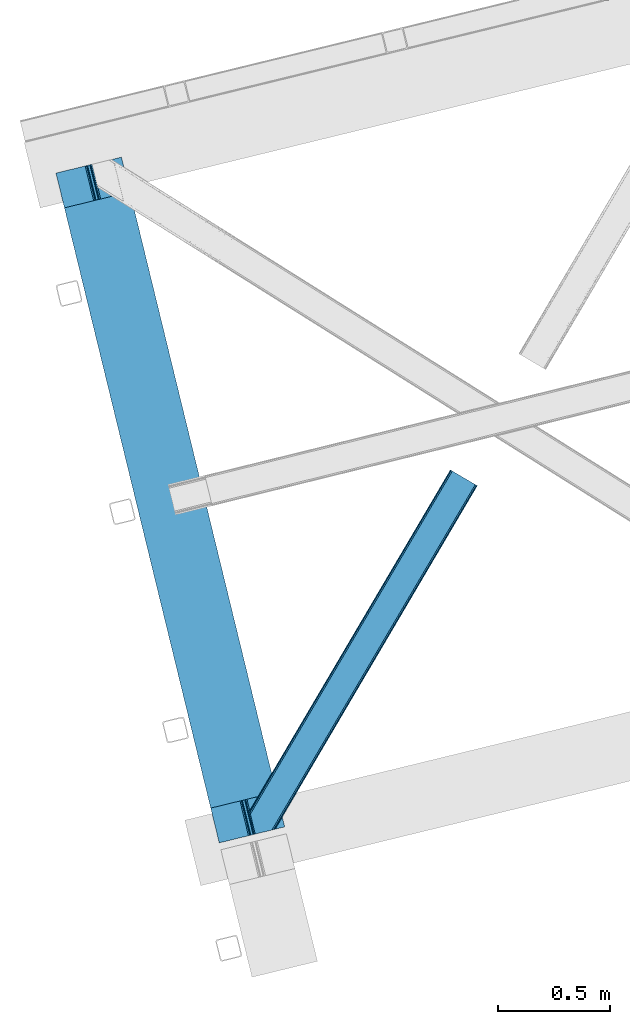
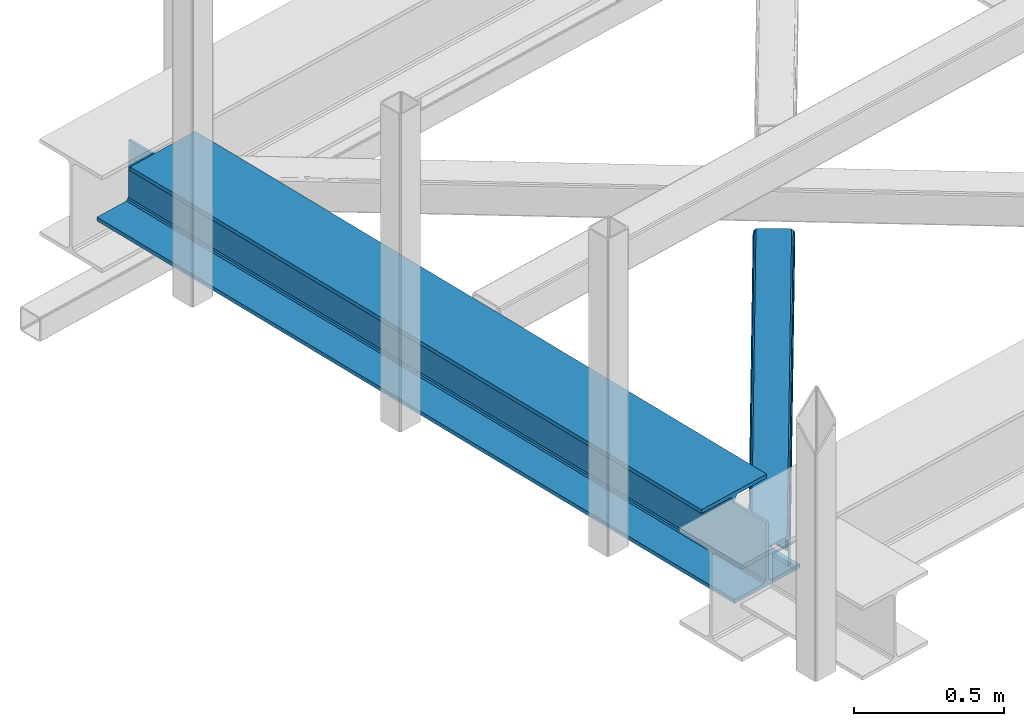
# One storey, part 17 of 66: 1 beam, 1 member.
"""IFC4 building model written with IfcOpenShell, lengths in millimetres."""

from ifc_helpers import new_model, entity, si_unit, converted_unit, derived_unit, direction, frame, origin, place, context, subcontext, project, spatial, triangles, polygons, material, type_object, element, save


model = new_model("IFC4")

# Units and contexts
model_context = context("Model", 3, precision=0.01, world=origin(), true_north=direction((6.12303176911189e-17, 1.0)))
plan_context = context("Plan", 3, precision=0.01, world=origin(), true_north=direction((6.12303176911189e-17, 1.0)))
body_context = subcontext(model_context, "Body", "Model", "MODEL_VIEW")
ifc_project = project(units=[si_unit("LENGTHUNIT", "METRE", prefix="MILLI"), si_unit("AREAUNIT", "SQUARE_METRE"), si_unit("VOLUMEUNIT", "CUBIC_METRE"), converted_unit("PLANEANGLEUNIT", "DEGREE", entity("IfcRatioMeasure", 0.0174532925199433), si_unit("PLANEANGLEUNIT", "RADIAN"), dimensions=[0, 0, 0, 0, 0, 0, 0]), si_unit("MASSUNIT", "GRAM", prefix="KILO"), derived_unit("MASSDENSITYUNIT", [(si_unit("MASSUNIT", "GRAM", prefix="KILO"), 1), (si_unit("LENGTHUNIT", "METRE"), -3)]), derived_unit("MOMENTOFINERTIAUNIT", [(si_unit("LENGTHUNIT", "METRE"), 4)]), si_unit("TIMEUNIT", "SECOND"), si_unit("FREQUENCYUNIT", "HERTZ"), si_unit("THERMODYNAMICTEMPERATUREUNIT", "DEGREE_CELSIUS"), derived_unit("THERMALTRANSMITTANCEUNIT", [(si_unit("MASSUNIT", "GRAM", prefix="KILO"), 1), (si_unit("THERMODYNAMICTEMPERATUREUNIT", "KELVIN"), -1), (si_unit("TIMEUNIT", "SECOND"), -3)]), derived_unit("VOLUMETRICFLOWRATEUNIT", [(si_unit("LENGTHUNIT", "METRE"), 3), (si_unit("TIMEUNIT", "SECOND"), -1)]), derived_unit("MASSFLOWRATEUNIT", [(si_unit("MASSUNIT", "GRAM", prefix="KILO"), 1), (si_unit("TIMEUNIT", "SECOND"), -1)]), derived_unit("ROTATIONALFREQUENCYUNIT", [(si_unit("TIMEUNIT", "SECOND"), -1)]), si_unit("ELECTRICCURRENTUNIT", "AMPERE"), si_unit("ELECTRICVOLTAGEUNIT", "VOLT"), si_unit("POWERUNIT", "WATT"), si_unit("FORCEUNIT", "NEWTON", prefix="KILO"), si_unit("ILLUMINANCEUNIT", "LUX"), si_unit("LUMINOUSFLUXUNIT", "LUMEN"), si_unit("LUMINOUSINTENSITYUNIT", "CANDELA"), derived_unit("USERDEFINED", [(si_unit("MASSUNIT", "GRAM", prefix="KILO"), -1), (si_unit("LENGTHUNIT", "METRE"), -2), (si_unit("TIMEUNIT", "SECOND"), 3), (si_unit("LUMINOUSFLUXUNIT", "LUMEN"), 1)]), derived_unit("LINEARVELOCITYUNIT", [(si_unit("LENGTHUNIT", "METRE"), 1), (si_unit("TIMEUNIT", "SECOND"), -1)]), si_unit("PRESSUREUNIT", "PASCAL"), derived_unit("USERDEFINED", [(si_unit("LENGTHUNIT", "METRE"), -2), (si_unit("MASSUNIT", "GRAM", prefix="KILO"), 1), (si_unit("TIMEUNIT", "SECOND"), -2)]), derived_unit("LINEARFORCEUNIT", [(si_unit("MASSUNIT", "GRAM", prefix="KILO"), 1), (si_unit("LENGTHUNIT", "METRE"), 1), (si_unit("TIMEUNIT", "SECOND"), -2), (si_unit("LENGTHUNIT", "METRE"), -1)]), derived_unit("PLANARFORCEUNIT", [(si_unit("MASSUNIT", "GRAM", prefix="KILO"), 1), (si_unit("LENGTHUNIT", "METRE"), 1), (si_unit("TIMEUNIT", "SECOND"), -2), (si_unit("LENGTHUNIT", "METRE"), -2)])], contexts=[model_context, plan_context])

# Site, building, storey
site_placement = place(None, origin())
site = spatial("IfcSite", under=ifc_project, at=site_placement, CompositionType="ELEMENT")
building_placement = place(site_placement, origin())
building = spatial("IfcBuilding", under=site, at=building_placement, CompositionType="ELEMENT")
storey_placement = place(building_placement, frame((0.0, 0.0, 19800.0)))
storey = spatial("IfcBuildingStorey", under=building, at=storey_placement, Name="06", CompositionType="ELEMENT", Elevation=19800.0)

# Beam
ifc_material = material(Name="Metal painted (White)")
beam_type = type_object("IfcBeamType", PredefinedType="BEAM")
beam_placement = place(storey_placement, frame((-61151.81, 2888.53, 3808.0)))
element("IfcBeam", 1, at=beam_placement, inside=storey, type_object=beam_type, material=ifc_material, ObjectType="Steel Beam", PredefinedType="BEAM", context=body_context, shape_type="Tessellation", body=[
    polygons([(291.465617442446, 3052.25531830421, 15.5000000000051), (1018.16648378329, 71.0478278971005, 15.5000000000051), (1018.16648378329, 71.0478278971005, 0.0), (291.465617442446, 3052.25531830421, 0.0), (168.078506058482, 3022.17840449444, 15.5000000000051), (894.779372399338, 40.9709140873275, 15.5000000000051), (888.087028625375, 39.3395844888227, 16.8701684148028), (161.38616228452, 3020.54707489594, 16.8701684148028), (882.413533524751, 37.9566100336502, 20.7720779386478), (155.712667183895, 3019.16410044076, 20.7720779386478), (878.622625296176, 37.0325360459167, 26.6116982174338), (151.92175895532, 3018.24002645303, 26.6116982174338), (877.291435352788, 36.7080444135018, 33.500000000001), (150.590569011924, 3017.91553482062, 33.500000000001), (140.875048430514, 3015.54727389071, 33.500000000001), (140.875048430514, 3015.54727389071, 259.000000000006), (150.590569011924, 3017.91553482062, 259.000000000006), (8.66293703438714e-12, 2981.20749040711, 4.33146851719357e-12), (8.66293703438714e-12, 2981.20749040711, 15.5000000000051), (123.387111383964, 3011.28440421689, 15.5000000000051), (130.079455157926, 3012.91573381539, 16.8701684148028), (135.752950258551, 3014.29870827056, 20.7720779386478), (139.543858487117, 3015.2227822583, 26.6116982174338), (867.575914771369, 34.3397834835981, 259.000000000006), (867.575914771369, 34.3397834835981, 33.500000000001), (866.244724827964, 34.0152918511832, 26.6116982174338), (862.453816599389, 33.0912178634492, 20.7720779386478), (856.780321498782, 31.7082434082773, 16.8701684148028), (850.087977724819, 30.0769138097725, 15.5000000000051), (726.700866340855, -5.41433564649196e-13, 15.5000000000051), (726.700866340855, -5.41433564649196e-13, 4.33146851719357e-12), (877.291435352779, 36.7080444135018, 259.000000000006), (839.723099725414, 190.827961666228, 259.069792599954), (188.068298227656, 2864.16742161973, 259.000000000006), (188.291691329488, 2863.25097721476, 259.617303331129), (188.304080173113, 2863.20015298098, 266.500003008253), (839.577920935824, 191.42343960925, 266.500002998871), (839.578271056576, 191.422003304517, 260.000004007593), (830.098162489501, 188.087889491629, 259.00634317046), (829.874792453787, 189.004341089458, 259.617303331129), (829.862403610171, 189.055165323232, 266.500003008253), (178.588562847469, 2860.83187869496, 266.500002998871), (178.588212726726, 2860.8333149997, 260.000004007593), (178.443407068381, 2861.42736381349, 259.076120467494), (178.352777646237, 2861.79916068982, 259.000000000006), (840.909408805742, 191.746709053936, 273.388305639792), (844.699685394447, 192.673374225849, 279.227924098781), (850.372756341977, 194.058088689526, 283.129832400619), (857.06494802311, 195.690042220339, 284.500000377228), (980.451976710963, 225.76729527545, 284.500000138975), (980.450306904294, 225.774145344182, 299.999995328161), (688.984884807024, 154.72551608014, 299.999995890966), (688.986554613684, 154.718666011408, 284.500000701776), (812.373583301528, 184.795919066519, 284.500000463524), (819.066070197667, 186.426661533098, 283.129832461069), (824.739981846427, 187.807927177623, 279.227924137327), (828.531516633419, 188.72943082692, 273.388305663689), (177.257074977542, 2860.50860925028, 273.388305639792), (173.466798388846, 2859.58194407836, 279.227924098781), (167.793727441316, 2858.19722961469, 283.129832400619), (161.101535760182, 2856.56527608388, 284.500000377228), (37.7145070723384, 2826.48802302876, 284.500000138975), (37.7161768789901, 2826.48117296003, 299.999995328161), (329.181598976269, 2897.52980222408, 299.999995890962), (329.1799291696, 2897.53665229281, 284.500000701776), (205.792900481765, 2867.4593992377, 284.500000463524), (199.100413585626, 2865.82865677112, 283.129832461069), (193.426501936857, 2864.44739112659, 279.227924137327), (189.634967149874, 2863.52588747729, 273.388305663689)], [[[1, 2, 3, 4]], [[5, 6, 2, 1]], [[7, 6, 5, 8]], [[9, 7, 8, 10]], [[11, 9, 10, 12]], [[13, 11, 12, 14]], [[15, 16, 17, 14, 12, 10, 8, 5, 1, 4, 18, 19, 20, 21, 22, 23]], [[24, 25, 26, 27, 28, 29, 30, 31, 3, 2, 6, 7, 9, 11, 13, 32]], [[4, 3, 31, 18]], [[18, 31, 30, 19]], [[19, 30, 29, 20]], [[26, 25, 15, 23]], [[27, 26, 23, 22]], [[28, 27, 22, 21]], [[29, 28, 21, 20]], [[33, 32, 13, 14, 17, 34, 35, 36, 37, 38]], [[24, 39, 40, 41, 42, 43, 44, 16, 15, 25]], [[39, 24, 32, 33]], [[45, 34, 17, 16]], [[41, 40, 38, 37, 46, 47, 48, 49, 50, 51, 52, 53, 54, 55, 56, 57]], [[42, 58, 59, 60, 61, 62, 63, 64, 65, 66, 67, 68, 69, 36, 35, 43]], [[46, 37, 36, 69]], [[47, 46, 69, 68]], [[48, 47, 68, 67]], [[49, 48, 67, 66]], [[50, 49, 66, 65]], [[51, 50, 65, 64]], [[52, 51, 64, 63]], [[53, 52, 63, 62]], [[54, 53, 62, 61]], [[55, 54, 61, 60]], [[56, 55, 60, 59]], [[57, 56, 59, 58]], [[41, 57, 58, 42]]], closed=False),
])

# Member
member_type = type_object("IfcMemberType", PredefinedType="BRACE")
member_placement = place(storey_placement, frame((-60290.05, 2927.62, 3824.0)))
element("IfcMember", 2, at=member_placement, inside=storey, type_object=member_type, ObjectType="Steel Horizontal Brace", PredefinedType="BRACE", context=body_context, shape_type="Tessellation", body=[
    triangles([(154.446386718751, 124.708666992187, 0.0), (118.769494628912, 271.071535491943, 0.0), (998.971582031256, 1559.19843292236, 0.0), (908.488732910162, 1612.46872787476, 0.0), (1004.74332275391, 1555.80096588135, 1.33247680664135), (156.720666503912, 115.373480987549, 1.33247680664135), (1009.63139648438, 1552.92061843872, 5.12526855468968), (158.650781250006, 107.459719848633, 5.12526855468968), (1012.90096435547, 1550.99602661133, 10.8039916992202), (159.939074707036, 102.171670532226, 10.8039916992202), (1014.04973144532, 1550.32019577026, 17.5012573242202), (160.39486083985, 100.314807128906, 17.5012573242202), (902.716992187503, 1615.86619491577, 1.33247680664135), (116.495214843751, 280.40643081665, 1.33247680664135), (114.574401855469, 288.275717926025, 5.1694519042976), (897.824267578129, 1618.74683303833, 5.12526855468968), (114.495336914064, 288.596628570557, 5.32758178711083), (894.554699707034, 1620.67142486572, 10.8039916992202), (109.625866699222, 287.408910369873, 10.8039916992202), (893.405932617192, 1621.34696502686, 17.5012573242202), (107.821325683595, 286.969111633301, 17.5012573242202), (113.523303222661, 288.35972442627, 18.5197998046897), (114.495336914064, 288.596628570557, 17.5198608398459), (114.420922851568, 288.578606414795, 17.9035583496116), (114.211633300787, 288.527156066894, 18.2267944335945), (113.895373535161, 288.450416564941, 18.4453857421868), (107.821325683595, 286.969111633301, 18.5197998046897), (115.695263671878, 283.683556365967, 17.5198608398459), (115.625500488284, 283.800409698486, 17.8035644531265), (115.565039062501, 283.740238952636, 17.8570495605491), (115.323193359378, 283.495486450195, 18.0779663085959), (115.067395019534, 283.239106750488, 18.3081848144539), (114.830200195313, 283.003074645996, 18.5197998046897), (0.0, 103.824476623535, 18.5197998046897), (2.73471679687646, 92.5987083435057, 18.5197998046897), (893.405932617192, 1621.34696502686, 122.499499511719), (0.0, 103.824476623535, 122.499499511719), (908.488732910162, 1612.46872787476, 140.00075683594), (902.716992187503, 1615.86619491577, 138.668280029298), (3.66954345703562, 88.7658027648927, 138.668280029298), (5.94382324218896, 79.430616760254, 140.00075683594), (897.824267578129, 1618.74683303833, 134.87548828125), (1.73942871094187, 96.6798545837401, 134.87548828125), (894.554699707034, 1620.67142486572, 129.196765136719), (0.451135253912071, 101.967613220215, 129.196765136719), (899.438122558597, 1617.795728302, 24.5008300781265), (2.37659912109666, 94.0669326782227, 24.5008300781265), (900.586889648439, 1617.11989746094, 17.8035644531265), (903.856457519534, 1615.19530563355, 12.1248413085959), (914.516271972658, 1608.9174911499, 6.99957275390625), (908.749182128908, 1612.31495819092, 8.3320495605476), (118.871813964848, 270.648886871338, 8.3320495605476), (121.146093750001, 261.313991546631, 6.99957275390625), (116.941699218754, 278.562938690186, 12.1248413085959), (152.069787597662, 134.4662109375, 6.99957275390625), (992.939392089844, 1562.74996032715, 6.99957275390625), (156.274182128909, 117.217263793945, 12.1248413085959), (154.344067382815, 125.131024932861, 8.3320495605476), (157.520617675786, 112.096646118164, 17.5198608398459), (160.39486083985, 100.314807128906, 17.5198608398459), (899.438122558597, 1617.795728302, 115.499926757813), (2.37659912109666, 94.0669326782227, 115.499926757813), (900.586889648439, 1617.11989746094, 122.197192382813), (2.82773437500146, 92.2100692749023, 122.197192382813), (903.856457519534, 1615.19530563355, 127.873590087893), (4.12067871094041, 86.9223106384275, 127.873590087893), (908.749182128908, 1612.31495819092, 131.668707275392), (6.046142578125, 79.0082588195801, 131.668707275392), (914.516271972658, 1608.9174911499, 133.001184082033), (8.3250732421875, 69.6733634948728, 133.001184082033), (25.3054321289092, 0.0, 133.001184082033), (25.3054321289092, 0.0, 140.00075683594), (90.3619262695356, 15.8580436706543, 140.00075683594), (998.971582031256, 1559.19843292236, 140.00075683594), (1014.04973144532, 1550.32019577026, 122.499499511719), (1012.90096435547, 1550.99602661133, 129.196765136719), (114.0721069336, 21.6376327514649, 122.499499511719), (112.267565917973, 21.1975433349608, 129.196765136719), (1009.63139648438, 1552.92061843872, 134.87548828125), (107.128344726567, 19.9447128295897, 134.87548828125), (1004.74332275391, 1555.80096588135, 138.668280029298), (99.435791015625, 18.0698272705076, 138.668280029298), (159.664672851563, 99.0785453796384, 18.5197998046897), (114.0721069336, 21.6376327514649, 18.5197998046897), (103.161145019534, 18.9779113769532, 18.5197998046897), (156.929956054693, 110.304313659668, 18.5197998046897), (1008.01754150391, 1553.87143249512, 24.5008300781265), (1006.86877441406, 1554.54726333618, 17.8035644531265), (157.222961425781, 111.200479888916, 18.0198303222678), (1003.59920654297, 1556.47185516357, 12.1248413085959), (998.706481933594, 1559.3522026062, 8.3320495605476), (104.588964843751, 19.325855255127, 24.5008300781265), (1003.59920654297, 1556.47185516357, 127.873590087893), (1008.01754150391, 1553.87143249512, 115.499926757813), (1006.86877441406, 1554.54726333618, 122.197192382813), (992.939392089844, 1562.74996032715, 133.001184082033), (998.706481933594, 1559.3522026062, 131.668707275392), (102.784423828125, 18.8857658386228, 122.197192382813), (80.8787841796875, 13.5462661743163, 133.001184082033), (89.9526489257842, 15.7577590942383, 131.668707275392), (97.6452026367188, 17.6329353332517, 127.873590087893), (104.588964843751, 19.325855255127, 115.499926757813)], [[1, 2, 3], [4, 3, 2], [3, 5, 1], [6, 1, 5], [5, 7, 6], [8, 6, 7], [7, 9, 8], [10, 8, 9], [9, 11, 10], [12, 10, 11], [13, 14, 15], [16, 15, 17], [17, 18, 16], [17, 19, 18], [20, 18, 19], [19, 21, 20], [15, 16, 13], [13, 4, 14], [2, 14, 4], [22, 23, 24], [22, 25, 26], [27, 21, 22], [24, 25, 22], [23, 22, 21], [21, 19, 23], [17, 23, 19], [23, 28, 29], [29, 24, 23], [25, 24, 30], [26, 25, 31], [22, 26, 32], [32, 33, 22], [31, 32, 26], [30, 31, 25], [29, 30, 24], [34, 33, 35], [33, 34, 27], [22, 33, 27], [27, 20, 21], [36, 27, 37], [27, 36, 20], [27, 34, 37], [38, 39, 40], [40, 41, 38], [39, 42, 43], [43, 40, 39], [42, 44, 45], [45, 43, 42], [44, 36, 37], [37, 45, 44], [46, 47, 33], [33, 48, 46], [33, 31, 48], [47, 35, 33], [49, 48, 28], [50, 51, 52], [52, 53, 50], [51, 49, 54], [54, 52, 51], [28, 54, 49], [53, 55, 56], [56, 50, 53], [55, 2, 1], [54, 17, 14], [52, 14, 2], [52, 2, 53], [55, 53, 2], [17, 28, 23], [54, 28, 17], [52, 54, 14], [57, 58, 6], [58, 1, 6], [1, 58, 55], [8, 57, 6], [8, 59, 57], [10, 59, 8], [10, 60, 59], [46, 61, 47], [62, 47, 61], [61, 63, 62], [64, 62, 63], [63, 65, 64], [66, 64, 65], [65, 67, 66], [68, 66, 67], [67, 69, 68], [70, 68, 69], [66, 43, 64], [71, 72, 70], [72, 41, 70], [40, 68, 41], [66, 68, 40], [68, 70, 41], [66, 40, 43], [37, 34, 62], [45, 64, 43], [62, 64, 37], [64, 45, 37], [34, 47, 62], [34, 35, 47], [41, 73, 74], [73, 41, 72], [74, 38, 41], [75, 76, 77], [78, 77, 76], [76, 79, 78], [80, 78, 79], [79, 81, 80], [82, 80, 81], [81, 74, 82], [73, 82, 74], [60, 75, 77], [60, 11, 75], [77, 83, 60], [77, 84, 83], [84, 85, 83], [86, 83, 85], [87, 88, 59], [89, 86, 87], [88, 90, 57], [57, 59, 88], [90, 91, 58], [58, 57, 90], [91, 56, 55], [55, 58, 91], [87, 86, 92], [85, 92, 86], [9, 90, 88], [87, 75, 11], [9, 88, 11], [9, 7, 90], [88, 87, 11], [90, 7, 5], [56, 3, 4], [3, 91, 5], [91, 3, 56], [91, 90, 5], [76, 93, 79], [94, 75, 87], [75, 95, 76], [95, 75, 94], [76, 95, 93], [74, 96, 38], [81, 79, 93], [93, 97, 81], [97, 96, 74], [74, 81, 97], [49, 13, 16], [4, 50, 56], [4, 51, 50], [51, 4, 13], [49, 51, 13], [46, 20, 36], [18, 48, 49], [16, 18, 49], [48, 18, 20], [46, 48, 20], [39, 65, 42], [38, 96, 69], [69, 67, 38], [67, 65, 39], [39, 38, 67], [44, 42, 65], [36, 61, 46], [63, 36, 44], [36, 63, 61], [63, 44, 65], [98, 78, 80], [99, 73, 72], [72, 71, 99], [99, 100, 73], [100, 82, 73], [101, 82, 100], [80, 82, 101], [98, 77, 78], [102, 77, 98], [80, 101, 98], [84, 92, 85], [102, 84, 77], [92, 84, 102], [99, 70, 96], [99, 71, 70], [69, 96, 70], [96, 97, 100], [100, 99, 96], [97, 93, 101], [101, 100, 97], [93, 95, 98], [98, 101, 93], [95, 94, 102], [102, 98, 95], [94, 87, 102], [92, 102, 87]]),
])

save(model, "model.ifc")
